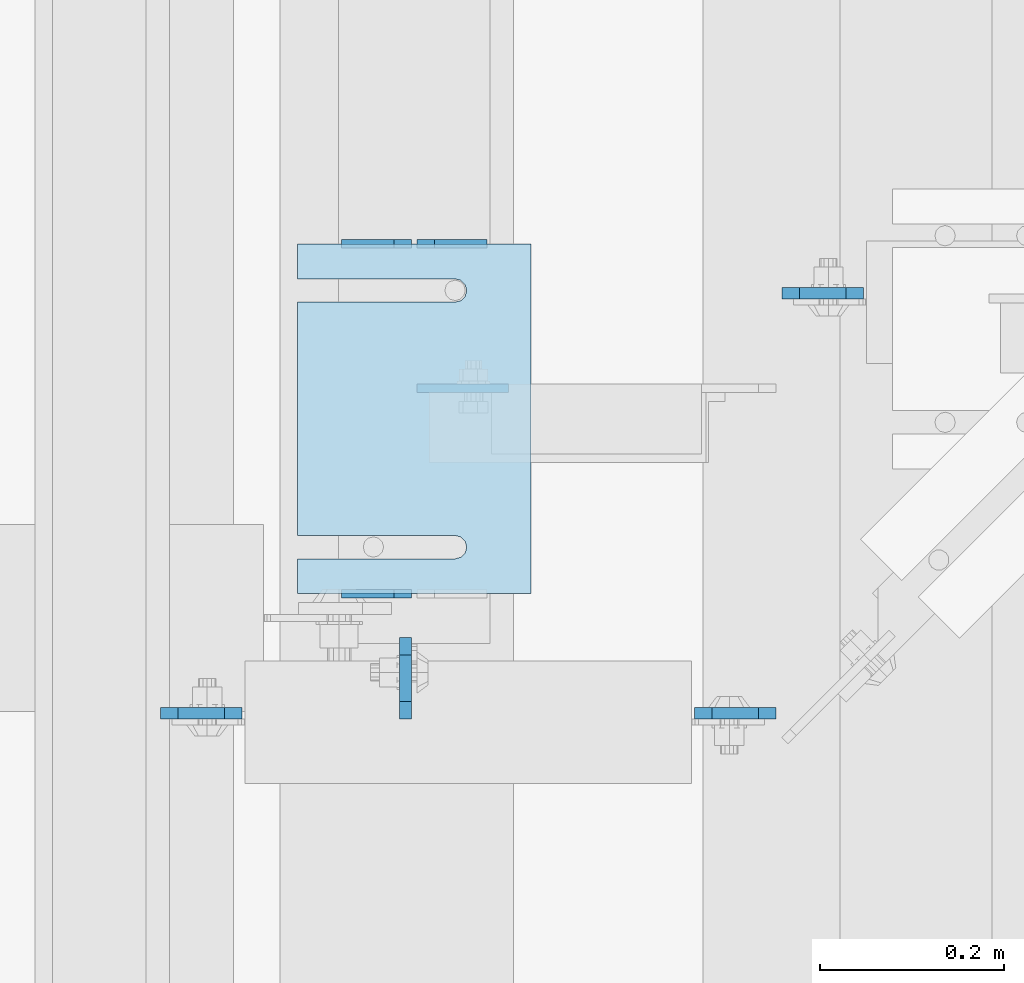
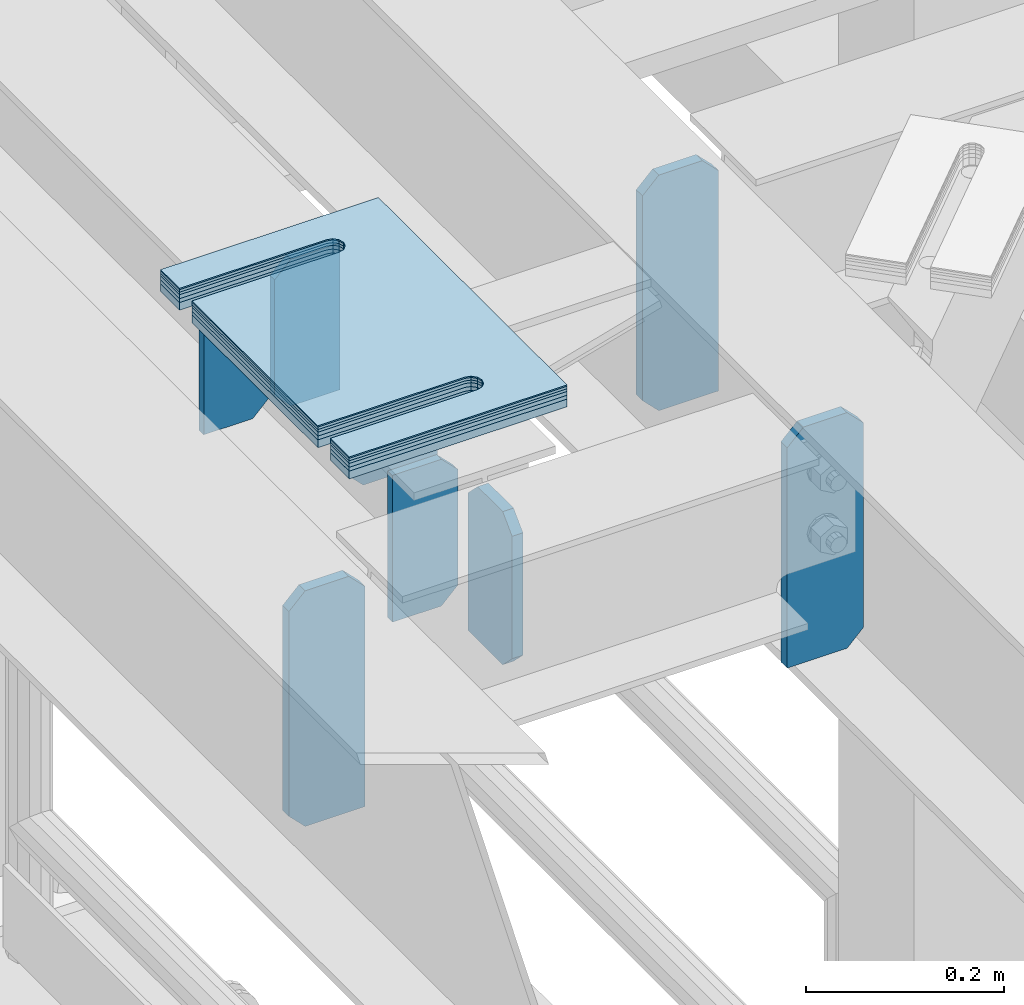
# One storey, part 1717 of 1876: 14 plates, 10 elements without a shape of their own.
"""IFC2X3 building model written with IfcOpenShell, lengths in millimetres."""

from ifc_helpers import new_model, si_unit, frame, origin_with_axes, place, context, subcontext, project, spatial, faceted_brep, material, type_object, element, aggregate, save


model = new_model("IFC2X3")

# Units and contexts
model_context = context("Model", 3, precision=1e-05, world=origin_with_axes())
body_context = subcontext(model_context, "Body", "Model", "MODEL_VIEW")
ifc_project = project(units=[si_unit("LENGTHUNIT", "METRE", prefix="MILLI"), si_unit("AREAUNIT", "SQUARE_METRE"), si_unit("VOLUMEUNIT", "CUBIC_METRE"), si_unit("MASSUNIT", "GRAM", prefix="KILO"), si_unit("TIMEUNIT", "SECOND"), si_unit("PLANEANGLEUNIT", "RADIAN"), si_unit("SOLIDANGLEUNIT", "STERADIAN"), si_unit("THERMODYNAMICTEMPERATUREUNIT", "DEGREE_CELSIUS"), si_unit("LUMINOUSINTENSITYUNIT", "LUMEN")], contexts=[model_context])

# Site, building, storey
site_placement = place(None, origin_with_axes())
site = spatial("IfcSite", under=ifc_project, at=site_placement, CompositionType="ELEMENT")
building_placement = place(site_placement, origin_with_axes())
building = spatial("IfcBuilding", under=site, at=building_placement, Name="Undefined", CompositionType="ELEMENT")
storey_placement = place(building_placement, origin_with_axes())
storey = spatial("IfcBuildingStorey", under=building, at=storey_placement, Name="Undefined", CompositionType="ELEMENT", Elevation=0.0)

# Assembly, plates
assembly_1_placement = place(storey_placement, origin_with_axes())
assembly_1 = element("IfcElementAssembly", 1, at=assembly_1_placement, inside=storey, Name="BEAM", AssemblyPlace="NOTDEFINED", PredefinedType="RIGID_FRAME")
ifc_material = material(Name="STEEL/A36")
plate_type_1 = type_object("IfcPlateType", PredefinedType="NOTDEFINED")
plate_1_placement = place(assembly_1_placement, frame((5102.22401450963, 6273.20592206104, 17792.7), z_axis=(0.0, 0.0, 1.0), x_axis=(-1.0, 0.0, 0.0)))
plate_1 = element("IfcPlate", 2, at=plate_1_placement, type_object=plate_type_1, material=ifc_material, Name="PLATE", context=body_context, shape_type="Brep", body=[
    faceted_brep([(0.0, -4.76249999999982, 19.0499992370605), (0.0, -4.76249999999982, 161.925006866455), (0.0, 4.76249999999982, 161.925006866455), (0.0, 4.76249999999982, 19.0499992370605), (19.0499992370605, -4.76249999999982, 180.975006103516), (19.0499992370605, 4.76249999999982, 180.975006103516), (76.1999969482422, -4.76249999999982, 180.975006103516), (76.1999969482422, 4.76249999999982, 180.975006103516), (76.1999969482422, -4.76250000000073, 0.0), (76.1999969482422, 4.76250000000073, 0.0), (19.0499992370605, -4.76249999999982, 0.0), (19.0499992370605, 4.76249999999982, 0.0)], [[[0, 1, 2, 3]], [[1, 4, 5, 2]], [[4, 6, 7, 5]], [[6, 8, 9, 7]], [[8, 10, 11, 9]], [[10, 0, 3, 11]], [[5, 7, 9, 11, 3, 2]], [[10, 8, 6, 4, 1, 0]]]),
])
plate_2_placement = place(assembly_1_placement, frame((5184.77401450963, 6654.2043980711, 17792.7), z_axis=(0.0, 0.0, 1.0), x_axis=(-1.0, 0.0, 0.0)))
plate_2 = element("IfcPlate", 3, at=plate_2_placement, type_object=plate_type_1, material=ifc_material, Name="PLATE", context=body_context, shape_type="Brep", body=[
    faceted_brep([(0.0, -4.76249999999982, 0.0), (0.0, -4.76249999999982, 180.975006103516), (0.0, 4.76249999999982, 180.975006103516), (0.0, 4.76249999999982, 0.0), (57.1499977111816, -4.76249999999982, 180.975006103516), (57.1499977111816, 4.76249999999982, 180.975006103516), (76.1999969482422, -4.76249999999982, 161.925006866455), (76.1999969482422, 4.76249999999982, 161.925006866455), (76.1999969482422, -4.76249999999982, 19.0499992370605), (76.1999969482422, 4.76249999999982, 19.0499992370605), (57.1499977111816, -4.76249999999982, 0.0), (57.1499977111816, 4.76249999999982, 0.0)], [[[0, 1, 2, 3]], [[1, 4, 5, 2]], [[4, 6, 7, 5]], [[6, 8, 9, 7]], [[8, 10, 11, 9]], [[10, 0, 3, 11]], [[5, 7, 9, 11, 3, 2]], [[10, 8, 6, 4, 1, 0]]]),
])
plate_3_placement = place(assembly_1_placement, frame((5102.22401450963, 6654.2043980711, 17792.7), z_axis=(0.0, 0.0, 1.0), x_axis=(-1.0, 0.0, 0.0)))
plate_3 = element("IfcPlate", 4, at=plate_3_placement, type_object=plate_type_1, material=ifc_material, Name="PLATE", context=body_context, shape_type="Brep", body=[
    faceted_brep([(0.0, -4.76249999999982, 19.0499992370605), (0.0, -4.76249999999982, 161.925006866455), (0.0, 4.76249999999982, 161.925006866455), (0.0, 4.76249999999982, 19.0499992370605), (19.0499992370605, -4.76249999999982, 180.975006103516), (19.0499992370605, 4.76249999999982, 180.975006103516), (76.1999969482422, -4.76249999999982, 180.975006103516), (76.1999969482422, 4.76249999999982, 180.975006103516), (76.1999969482422, -4.76250000000073, 0.0), (76.1999969482422, 4.76250000000073, 0.0), (19.0499992370605, -4.76249999999982, 0.0), (19.0499992370605, 4.76249999999982, 0.0)], [[[0, 1, 2, 3]], [[1, 4, 5, 2]], [[4, 6, 7, 5]], [[6, 8, 9, 7]], [[8, 10, 11, 9]], [[10, 0, 3, 11]], [[5, 7, 9, 11, 3, 2]], [[10, 8, 6, 4, 1, 0]]]),
])
plate_type_2 = type_object("IfcPlateType", PredefinedType="NOTDEFINED")
plate_4_placement = place(assembly_1_placement, frame((5108.57399250517, 6497.04279828961, 17882.089493609), z_axis=(1.0, 0.0, 0.0), x_axis=(0.0, 0.0, -1.0)))
plate_4 = element("IfcPlate", 5, at=plate_4_placement, type_object=plate_type_2, material=ifc_material, Name="PLATE", context=body_context, shape_type="Brep", body=[
    faceted_brep([(0.0, -4.76249999999982, 0.0), (6.45964610157534e-06, -4.76250000002437, 99.4752502441406), (6.45964610157534e-06, 4.76249999997526, 99.4752502441424), (0.0, 4.76249999999982, 0.0), (89.3894958496094, -4.76250000002437, 99.4752502441406), (89.3894958496094, 4.76249999997526, 99.4752502441424), (89.3894891942582, -4.76250000000346, 12.6999998092715), (89.3894891942582, 4.76249999999709, 12.6999998092733), (76.6894884109497, -4.76249999999982, 5.45696821063757e-12), (76.6894884109497, 4.76249999999982, 7.27595761418343e-12)], [[[0, 1, 2, 3]], [[1, 4, 5, 2]], [[4, 6, 7, 5]], [[6, 8, 9, 7]], [[8, 0, 3, 9]], [[5, 7, 9, 3, 2]], [[8, 6, 4, 1, 0]]]),
])
aggregate(assembly_1, [plate_1, plate_2, plate_3, plate_4])

assembly_2_placement = place(storey_placement, origin_with_axes())
assembly_2 = element("IfcElementAssembly", 6, at=assembly_2_placement, inside=storey, Name="BEAM", AssemblyPlace="NOTDEFINED", PredefinedType="RIGID_FRAME")
plate_type_3 = type_object("IfcPlateType", PredefinedType="NOTDEFINED")
plate_5_placement = place(assembly_2_placement, frame((5505.45, 6600.23089609146, 17681.575), z_axis=(0.0, 0.0, 1.0), x_axis=(1.0, 0.0, 0.0)))
plate_5 = element("IfcPlate", 7, at=plate_5_placement, type_object=plate_type_3, material=ifc_material, Name="PLATE", context=body_context, shape_type="Brep", body=[
    faceted_brep([(0.0, -6.35000000000196, 19.0499992370605), (0.0, -6.35000000000036, 271.462512969971), (0.0, 6.35000000000036, 271.462512969971), (0.0, 6.35000000000105, 19.0499992370605), (19.0499992370605, -6.35000000000036, 290.512512207031), (19.0499992370605, 6.35000000000036, 290.512512207031), (69.8500003814697, -6.34999999999991, 290.512512207031), (69.8500003814697, 6.34999999999991, 290.512512207031), (88.9000015258789, -6.35000000000036, 271.462512969971), (88.9000015258789, 6.35000000000036, 271.462512969971), (88.9000015258789, -6.34999999999991, 0.0), (88.9000015258789, 6.34999999999991, 0.0), (19.0499992370642, -6.35000000000105, 0.0), (19.0499992370633, 6.35000000000105, 0.0)], [[[0, 1, 2, 3]], [[1, 4, 5, 2]], [[4, 6, 7, 5]], [[6, 8, 9, 7]], [[8, 10, 11, 9]], [[10, 12, 13, 11]], [[12, 0, 3, 13]], [[5, 7, 9, 11, 13, 3, 2]], [[12, 10, 8, 6, 4, 1, 0]]]),
])
plate_6_placement = place(assembly_2_placement, frame((5499.1, 6143.03089609146, 17681.575), z_axis=(0.0, 0.0, 1.0), x_axis=(-1.0, 0.0, 0.0)))
plate_6 = element("IfcPlate", 8, at=plate_6_placement, type_object=plate_type_3, material=ifc_material, Name="PLATE", context=body_context, shape_type="Brep", body=[
    faceted_brep([(0.0, -6.35000000000196, 19.0499992370605), (0.0, -6.35000000000036, 271.462512969971), (0.0, 6.35000000000036, 271.462512969971), (0.0, 6.35000000000105, 19.0499992370605), (19.0499992370605, -6.35000000000036, 290.512512207031), (19.0499992370605, 6.35000000000036, 290.512512207031), (69.8500003814697, -6.34999999999991, 290.512512207031), (69.8500003814697, 6.34999999999991, 290.512512207031), (88.9000015258789, -6.35000000000036, 271.462512969971), (88.9000015258789, 6.35000000000036, 271.462512969971), (88.9000015258789, -6.34999999999991, 0.0), (88.9000015258789, 6.34999999999991, 0.0), (19.0499992370642, -6.35000000000105, 0.0), (19.0499992370633, 6.35000000000105, 0.0)], [[[0, 1, 2, 3]], [[1, 4, 5, 2]], [[4, 6, 7, 5]], [[6, 8, 9, 7]], [[8, 10, 11, 9]], [[10, 12, 13, 11]], [[12, 0, 3, 13]], [[5, 7, 9, 11, 13, 3, 2]], [[12, 10, 8, 6, 4, 1, 0]]]),
])
aggregate(assembly_2, [plate_5, plate_6])

# Assembly, plate
assembly_3_placement = place(storey_placement, origin_with_axes())
assembly_3 = element("IfcElementAssembly", 9, at=assembly_3_placement, inside=storey, Name="BEAM", AssemblyPlace="NOTDEFINED", PredefinedType="RIGID_FRAME")
plate_7_placement = place(assembly_3_placement, frame((4829.175, 6143.03089609146, 17683.1625), z_axis=(0.0, 0.0, 1.0), x_axis=(1.0, 0.0, 0.0)))
plate_7 = element("IfcPlate", 10, at=plate_7_placement, type_object=plate_type_3, material=ifc_material, Name="PLATE", context=body_context, shape_type="Brep", body=[
    faceted_brep([(0.0, -6.35000000000196, 19.0499992370605), (0.0, -6.35000000000036, 271.462512969971), (0.0, 6.35000000000036, 271.462512969971), (0.0, 6.35000000000105, 19.0499992370605), (19.0499992370605, -6.35000000000036, 290.512512207031), (19.0499992370605, 6.35000000000036, 290.512512207031), (69.8500003814697, -6.34999999999991, 290.512512207031), (69.8500003814697, 6.34999999999991, 290.512512207031), (88.9000015258789, -6.35000000000036, 271.462512969971), (88.9000015258789, 6.35000000000036, 271.462512969971), (88.9000015258789, -6.34999999999991, 0.0), (88.9000015258789, 6.34999999999991, 0.0), (19.0499992370642, -6.35000000000105, 0.0), (19.0499992370633, 6.35000000000105, 0.0)], [[[0, 1, 2, 3]], [[1, 4, 5, 2]], [[4, 6, 7, 5]], [[6, 8, 9, 7]], [[8, 10, 11, 9]], [[10, 12, 13, 11]], [[12, 0, 3, 13]], [[5, 7, 9, 11, 13, 3, 2]], [[12, 10, 8, 6, 4, 1, 0]]]),
])
aggregate(assembly_3, [plate_7])

assembly_4_placement = place(storey_placement, origin_with_axes())
assembly_4 = element("IfcElementAssembly", 11, at=assembly_4_placement, inside=storey, Name="BEAM", AssemblyPlace="NOTDEFINED", PredefinedType="RIGID_FRAME")
plate_8_placement = place(assembly_4_placement, frame((5095.87401441426, 6136.68089599609, 17786.35), z_axis=(0.0, 0.0, 1.0), x_axis=(0.0, 1.0, 0.0)))
plate_8 = element("IfcPlate", 12, at=plate_8_placement, type_object=plate_type_3, material=ifc_material, Name="PLATE", context=body_context, shape_type="Brep", body=[
    faceted_brep([(0.0, -6.35000000000196, 19.0499992370605), (0.0, -6.34999999999991, 169.862506866455), (0.0, 6.34999999999991, 169.862506866455), (0.0, 6.35000000000105, 19.0499992370605), (19.0499992370605, -6.34999999999991, 188.912506103516), (19.0499992370605, 6.34999999999991, 188.912506103516), (69.8500022888184, -6.34999999999991, 188.912506103516), (69.8500022888184, 6.34999999999991, 188.912506103516), (88.9000015258789, -6.34999999999991, 169.862506866455), (88.9000015258789, 6.34999999999991, 169.862506866455), (88.9000015258789, -6.34999999999991, 0.0), (88.9000015258789, 6.34999999999991, 0.0), (19.0499992370642, -6.35000000000105, 0.0), (19.0499992370633, 6.35000000000105, 0.0)], [[[0, 1, 2, 3]], [[1, 4, 5, 2]], [[4, 6, 7, 5]], [[6, 8, 9, 7]], [[8, 10, 11, 9]], [[10, 12, 13, 11]], [[12, 0, 3, 13]], [[5, 7, 9, 11, 13, 3, 2]], [[12, 10, 8, 6, 4, 1, 0]]]),
])
aggregate(assembly_4, [plate_8])

assembly_5_placement = place(storey_placement, origin_with_axes())
assembly_5 = element("IfcElementAssembly", 13, at=assembly_5_placement, inside=storey, Name="SHIM PLATE", AssemblyPlace="NOTDEFINED", PredefinedType="RIGID_FRAME")
plate_type_4 = type_object("IfcPlateType", PredefinedType="NOTDEFINED")
plate_9_placement = place(assembly_5_placement, frame((5232.39982977416, 6654.20335755462, 18007.0115), z_axis=(-1.0, 0.0, 0.0), x_axis=(0.0, -1.0, 0.0)))
plate_9 = element("IfcPlate", 14, at=plate_9_placement, type_object=plate_type_4, material=ifc_material, Name="SHIM PLATE", context=body_context, shape_type="Brep", body=[
    faceted_brep([(38.1710562683074, -1.58750000000146, 253.999557495119), (38.1732778844053, -1.58750000000146, 82.6182316462764), (38.1732778844053, 1.58750000000146, 82.6182316462764), (38.1710562683074, 1.58750000000146, 253.999557495119), (39.8747477728821, -1.58750000000146, 76.2682283464169), (39.8747477728821, 1.58750000000146, 76.2682283464169), (44.523266268131, -1.58750000000146, 71.6196998169826), (44.523266268131, 1.58750000000146, 71.6196998169826), (50.8732658952267, -1.58750000000146, 69.9182162215529), (50.8732658952267, 1.58750000000146, 69.9182162215529), (57.2232684284982, -1.58750000000146, 71.6196889709886), (57.2232684284982, 1.58750000000146, 71.6196889709886), (61.8717948635667, -1.58750000000146, 76.2682095606051), (61.8717948635667, 1.58750000000146, 76.2682095606051), (63.5732755980398, -1.58750000000146, 82.6182099542939), (63.5732755980398, 1.58750000000146, 82.6182099542939), (63.5710539816291, -1.58750000000146, 253.999557596195), (63.5710539816291, 1.58750000000146, 253.99955749512), (9.09494701772928e-13, -1.58750000000146, 4.54747350886464e-13), (1.89071320164658e-05, -1.58750000000146, 253.999557495117), (1.89071320164658e-05, 1.58750000000146, 253.999557495117), (9.09494701772928e-13, 1.58750000000146, 4.54747350886464e-13), (380.998474121094, -1.58750000000146, -2.41016095969826e-11), (380.998474121094, 1.58750000000146, -2.41016095969826e-11), (380.998504638661, -1.58750000000146, 253.999557495133), (380.998504638661, 1.58750000000146, 253.999557495133), (342.971054337228, 1.58750000000146, 253.999557495132), (342.971054337228, -1.58750000000146, 253.999557596208), (342.973275782132, 1.58750000000146, 82.6182252130961), (342.973275782132, -1.58750000000146, 82.6182252130961), (341.271801399192, 1.58750000000146, 76.2682205744086), (341.271801399192, -1.58750000000146, 76.2682205744086), (336.623277411347, 1.58750000000146, 71.6196940636119), (336.623277411347, -1.58750000000146, 71.6196940636119), (330.273273696123, 1.58750000000146, 69.9182162342554), (330.273273696123, -1.58750000000146, 69.9182162342554), (323.923270846187, 1.58750000000146, 71.6196972929051), (323.923270846187, -1.58750000000146, 71.6196972929051), (319.274749222349, 1.58750000000146, 76.2682261677069), (319.274749222349, -1.58750000000146, 76.2682261677069), (317.573278068704, 1.58750000000146, 82.6182316716777), (317.573278068704, -1.58750000000146, 82.6182316716777), (317.571056623908, -1.58750000000146, 253.99955749513), (317.571056623908, 1.58750000000146, 253.99955749513)], [[[0, 1, 2, 3]], [[4, 5, 2, 1]], [[6, 7, 5, 4]], [[8, 9, 7, 6]], [[10, 11, 9, 8]], [[12, 13, 11, 10]], [[14, 15, 13, 12]], [[16, 17, 15, 14]], [[18, 19, 20, 21]], [[22, 18, 21, 23]], [[24, 22, 23, 25]], [[24, 25, 26, 27]], [[27, 26, 28, 29]], [[29, 28, 30, 31]], [[31, 30, 32, 33]], [[33, 32, 34, 35]], [[35, 34, 36, 37]], [[37, 36, 38, 39]], [[39, 38, 40, 41]], [[42, 41, 40, 43]], [[12, 10, 8, 6, 4, 1, 0, 19, 18, 22, 24, 27, 29, 31, 33, 35, 37, 39, 41, 42, 16, 14]], [[20, 19, 0, 3]], [[43, 40, 38, 36, 34, 32, 30, 28, 26, 25, 23, 21, 20, 3, 2, 5, 7, 9, 11, 13, 15, 17]], [[42, 43, 17, 16]]]),
])
aggregate(assembly_5, [plate_9])

assembly_6_placement = place(storey_placement, origin_with_axes())
assembly_6 = element("IfcElementAssembly", 15, at=assembly_6_placement, inside=storey, Name="SHIM PLATE", AssemblyPlace="NOTDEFINED", PredefinedType="RIGID_FRAME")
plate_10_placement = place(assembly_6_placement, frame((5232.39982977416, 6654.20335755462, 18003.8365), z_axis=(-1.0, 0.0, 0.0), x_axis=(0.0, -1.0, 0.0)))
plate_10 = element("IfcPlate", 16, at=plate_10_placement, type_object=plate_type_4, material=ifc_material, Name="SHIM PLATE", context=body_context, shape_type="Brep", body=[
    faceted_brep([(38.1710562683074, -1.58750000000146, 253.999557495119), (38.1732778844053, -1.58750000000146, 82.6182316462764), (38.1732778844053, 1.58750000000146, 82.6182316462764), (38.1710562683074, 1.58750000000146, 253.999557495119), (39.8747477728821, -1.58750000000146, 76.2682283464169), (39.8747477728821, 1.58750000000146, 76.2682283464169), (44.523266268131, -1.58750000000146, 71.6196998169826), (44.523266268131, 1.58750000000146, 71.6196998169826), (50.8732658952267, -1.58750000000146, 69.9182162215529), (50.8732658952267, 1.58750000000146, 69.9182162215529), (57.2232684284982, -1.58750000000146, 71.6196889709886), (57.2232684284982, 1.58750000000146, 71.6196889709886), (61.8717948635667, -1.58750000000146, 76.2682095606051), (61.8717948635667, 1.58750000000146, 76.2682095606051), (63.5732755980398, -1.58750000000146, 82.6182099542939), (63.5732755980398, 1.58750000000146, 82.6182099542939), (63.5710539816291, -1.58750000000146, 253.999557596195), (63.5710539816291, 1.58750000000146, 253.99955749512), (9.09494701772928e-13, -1.58750000000146, 4.54747350886464e-13), (1.89071320164658e-05, -1.58750000000146, 253.999557495117), (1.89071320164658e-05, 1.58750000000146, 253.999557495117), (9.09494701772928e-13, 1.58750000000146, 4.54747350886464e-13), (380.998474121094, -1.58750000000146, -2.41016095969826e-11), (380.998474121094, 1.58750000000146, -2.41016095969826e-11), (380.998504638661, -1.58750000000146, 253.999557495133), (380.998504638661, 1.58750000000146, 253.999557495133), (342.971054337228, 1.58750000000146, 253.999557495132), (342.971054337228, -1.58750000000146, 253.999557596208), (342.973275782132, 1.58750000000146, 82.6182252130961), (342.973275782132, -1.58750000000146, 82.6182252130961), (341.271801399192, 1.58750000000146, 76.2682205744086), (341.271801399192, -1.58750000000146, 76.2682205744086), (336.623277411347, 1.58750000000146, 71.6196940636119), (336.623277411347, -1.58750000000146, 71.6196940636119), (330.273273696123, 1.58750000000146, 69.9182162342554), (330.273273696123, -1.58750000000146, 69.9182162342554), (323.923270846187, 1.58750000000146, 71.6196972929051), (323.923270846187, -1.58750000000146, 71.6196972929051), (319.274749222349, 1.58750000000146, 76.2682261677069), (319.274749222349, -1.58750000000146, 76.2682261677069), (317.573278068704, 1.58750000000146, 82.6182316716777), (317.573278068704, -1.58750000000146, 82.6182316716777), (317.571056623908, -1.58750000000146, 253.99955749513), (317.571056623908, 1.58750000000146, 253.99955749513)], [[[0, 1, 2, 3]], [[4, 5, 2, 1]], [[6, 7, 5, 4]], [[8, 9, 7, 6]], [[10, 11, 9, 8]], [[12, 13, 11, 10]], [[14, 15, 13, 12]], [[16, 17, 15, 14]], [[18, 19, 20, 21]], [[22, 18, 21, 23]], [[24, 22, 23, 25]], [[24, 25, 26, 27]], [[27, 26, 28, 29]], [[29, 28, 30, 31]], [[31, 30, 32, 33]], [[33, 32, 34, 35]], [[35, 34, 36, 37]], [[37, 36, 38, 39]], [[39, 38, 40, 41]], [[42, 41, 40, 43]], [[12, 10, 8, 6, 4, 1, 0, 19, 18, 22, 24, 27, 29, 31, 33, 35, 37, 39, 41, 42, 16, 14]], [[20, 19, 0, 3]], [[43, 40, 38, 36, 34, 32, 30, 28, 26, 25, 23, 21, 20, 3, 2, 5, 7, 9, 11, 13, 15, 17]], [[42, 43, 17, 16]]]),
])
aggregate(assembly_6, [plate_10])

assembly_7_placement = place(storey_placement, origin_with_axes())
assembly_7 = element("IfcElementAssembly", 17, at=assembly_7_placement, inside=storey, Name="SHIM PLATE", AssemblyPlace="NOTDEFINED", PredefinedType="RIGID_FRAME")
plate_type_5 = type_object("IfcPlateType", PredefinedType="NOTDEFINED")
plate_11_placement = place(assembly_7_placement, frame((5232.39982977416, 6654.20335755462, 18009.3925), z_axis=(-1.0, 0.0, 0.0), x_axis=(0.0, -1.0, 0.0)))
plate_11 = element("IfcPlate", 18, at=plate_11_placement, type_object=plate_type_5, material=ifc_material, Name="SHIM PLATE", context=body_context, shape_type="Brep", body=[
    faceted_brep([(38.1710562683074, -0.793499999999767, 253.999557495119), (38.1732778844053, -0.793499999999767, 82.6182316462764), (38.1732778844053, 0.793499999999767, 82.6182316462764), (38.1710562683074, 0.793499999999767, 253.999557495119), (39.8747477728821, -0.793499999999767, 76.2682283464169), (39.8747477728821, 0.793499999999767, 76.2682283464169), (44.523266268131, -0.793499999999767, 71.6196998169826), (44.523266268131, 0.793499999999767, 71.6196998169826), (50.8732658952267, -0.793499999999767, 69.9182162215529), (50.8732658952267, 0.793499999999767, 69.9182162215529), (57.2232684284982, -0.793499999999767, 71.6196889709886), (57.2232684284982, 0.793499999999767, 71.6196889709886), (61.8717948635667, -0.793499999999767, 76.2682095606051), (61.8717948635667, 0.793499999999767, 76.2682095606051), (63.5732755980398, -0.793499999999767, 82.6182099542939), (63.5732755980398, 0.793499999999767, 82.6182099542939), (63.5710539816291, -0.793499999999767, 253.999557596195), (63.5710539816291, 0.793499999999767, 253.99955749512), (9.09494701772928e-13, -0.793499999999767, 0.0), (1.89070156011439e-05, -0.793499999999767, 253.999557495117), (1.89070156011439e-05, 0.793499999999767, 253.999557495117), (9.09494701772928e-13, 0.793499999999767, 0.0), (380.998474121094, -0.793499999999767, -2.41016095969826e-11), (380.998474121094, 0.793499999999767, -2.41016095969826e-11), (380.998504638661, -0.793499999999767, 253.999557495133), (380.998504638661, 0.793499999999767, 253.999557495133), (342.971054337228, 0.793499999999767, 253.999557495132), (342.971054337228, -0.793499999999767, 253.999557596208), (342.973275782132, 0.793499999999767, 82.6182252130961), (342.973275782132, -0.793499999999767, 82.6182252130961), (341.271801399192, 0.793499999999767, 76.2682205744086), (341.271801399192, -0.793499999999767, 76.2682205744086), (336.623277411347, 0.793499999999767, 71.6196940636119), (336.623277411347, -0.793499999999767, 71.6196940636119), (330.273273696123, 0.793499999999767, 69.9182162342554), (330.273273696123, -0.793499999999767, 69.9182162342554), (323.923270846187, 0.793499999999767, 71.6196972929051), (323.923270846187, -0.793499999999767, 71.6196972929051), (319.274749222349, 0.793499999999767, 76.2682261677069), (319.274749222349, -0.793499999999767, 76.2682261677069), (317.573278068704, 0.793499999999767, 82.6182316716777), (317.573278068704, -0.793499999999767, 82.6182316716777), (317.571056623908, -0.793499999999767, 253.99955749513), (317.571056623908, 0.793499999999767, 253.99955749513)], [[[0, 1, 2, 3]], [[4, 5, 2, 1]], [[6, 7, 5, 4]], [[8, 9, 7, 6]], [[10, 11, 9, 8]], [[12, 13, 11, 10]], [[14, 15, 13, 12]], [[16, 17, 15, 14]], [[18, 19, 20, 21]], [[22, 18, 21, 23]], [[24, 22, 23, 25]], [[24, 25, 26, 27]], [[27, 26, 28, 29]], [[29, 28, 30, 31]], [[31, 30, 32, 33]], [[33, 32, 34, 35]], [[35, 34, 36, 37]], [[37, 36, 38, 39]], [[39, 38, 40, 41]], [[42, 41, 40, 43]], [[12, 10, 8, 6, 4, 1, 0, 19, 18, 22, 24, 27, 29, 31, 33, 35, 37, 39, 41, 42, 16, 14]], [[20, 19, 0, 3]], [[43, 40, 38, 36, 34, 32, 30, 28, 26, 25, 23, 21, 20, 3, 2, 5, 7, 9, 11, 13, 15, 17]], [[42, 43, 17, 16]]]),
])
aggregate(assembly_7, [plate_11])

assembly_8_placement = place(storey_placement, origin_with_axes())
assembly_8 = element("IfcElementAssembly", 19, at=assembly_8_placement, inside=storey, Name="SHIM PLATE", AssemblyPlace="NOTDEFINED", PredefinedType="RIGID_FRAME")
plate_type_6 = type_object("IfcPlateType", PredefinedType="NOTDEFINED")
plate_12_placement = place(assembly_8_placement, frame((5232.39982977416, 6654.20335755462, 17999.868), z_axis=(-1.0, 0.0, 0.0), x_axis=(0.0, -1.0, 0.0)))
plate_12 = element("IfcPlate", 20, at=plate_12_placement, type_object=plate_type_6, material=ifc_material, Name="SHIM PLATE", context=body_context, shape_type="Brep", body=[
    faceted_brep([(38.1710562683056, -2.38100000000122, 253.999557495119), (38.1732778844034, -2.38100000000122, 82.6182316462764), (38.1732778844034, 2.38100000000122, 82.6182316462764), (38.1710562683056, 2.38100000000122, 253.999557495119), (39.8747477728803, -2.38100000000122, 76.2682283464169), (39.8747477728803, 2.38100000000122, 76.2682283464169), (44.5232662681292, -2.38100000000122, 71.6196998169826), (44.5232662681292, 2.38100000000122, 71.6196998169826), (50.8732658952249, -2.38100000000122, 69.9182162215529), (50.8732658952249, 2.38100000000122, 69.9182162215529), (57.2232684284963, -2.38100000000122, 71.6196889709886), (57.2232684284963, 2.38100000000122, 71.6196889709886), (61.8717948635649, -2.38100000000122, 76.2682095606051), (61.8717948635649, 2.38100000000122, 76.2682095606051), (63.573275598038, -2.38100000000122, 82.6182099542939), (63.573275598038, 2.38100000000122, 82.6182099542939), (63.5710539816273, -2.38100000000122, 253.999557596195), (63.5710539816273, 2.38100000000122, 253.99955749512), (0.0, -2.38100000000122, 4.54747350886464e-13), (1.89072484317876e-05, -2.38100000000122, 253.999557495117), (1.89072484317876e-05, 2.38100000000122, 253.999557495117), (0.0, 2.38100000000122, 4.54747350886464e-13), (380.998474121094, -2.38100000000122, -2.41016095969826e-11), (380.998474121094, 2.38100000000122, -2.41016095969826e-11), (380.998504638661, -2.38100000000122, 253.999557495133), (380.998504638661, 2.38100000000122, 253.999557495133), (342.971054337227, 2.38100000000122, 253.999557495132), (342.971054337227, -2.38100000000122, 253.999557596208), (342.97327578213, 2.38100000000122, 82.6182252130961), (342.97327578213, -2.38100000000122, 82.6182252130961), (341.27180139919, 2.38100000000122, 76.2682205744086), (341.27180139919, -2.38100000000122, 76.2682205744086), (336.623277411345, 2.38100000000122, 71.6196940636119), (336.623277411345, -2.38100000000122, 71.6196940636119), (330.273273696122, 2.38100000000122, 69.9182162342554), (330.273273696122, -2.38100000000122, 69.9182162342554), (323.923270846185, 2.38100000000122, 71.6196972929051), (323.923270846185, -2.38100000000122, 71.6196972929051), (319.274749222347, 2.38100000000122, 76.2682261677069), (319.274749222347, -2.38100000000122, 76.2682261677069), (317.573278068702, 2.38100000000122, 82.6182316716777), (317.573278068702, -2.38100000000122, 82.6182316716777), (317.571056623906, -2.38100000000122, 253.99955749513), (317.571056623906, 2.38100000000122, 253.99955749513)], [[[0, 1, 2, 3]], [[4, 5, 2, 1]], [[6, 7, 5, 4]], [[8, 9, 7, 6]], [[10, 11, 9, 8]], [[12, 13, 11, 10]], [[14, 15, 13, 12]], [[16, 17, 15, 14]], [[18, 19, 20, 21]], [[22, 18, 21, 23]], [[24, 22, 23, 25]], [[24, 25, 26, 27]], [[27, 26, 28, 29]], [[29, 28, 30, 31]], [[31, 30, 32, 33]], [[33, 32, 34, 35]], [[35, 34, 36, 37]], [[37, 36, 38, 39]], [[39, 38, 40, 41]], [[42, 41, 40, 43]], [[12, 10, 8, 6, 4, 1, 0, 19, 18, 22, 24, 27, 29, 31, 33, 35, 37, 39, 41, 42, 16, 14]], [[20, 19, 0, 3]], [[43, 40, 38, 36, 34, 32, 30, 28, 26, 25, 23, 21, 20, 3, 2, 5, 7, 9, 11, 13, 15, 17]], [[42, 43, 17, 16]]]),
])
aggregate(assembly_8, [plate_12])

assembly_9_placement = place(storey_placement, origin_with_axes())
assembly_9 = element("IfcElementAssembly", 21, at=assembly_9_placement, inside=storey, Name="SHIM PLATE", AssemblyPlace="NOTDEFINED", PredefinedType="RIGID_FRAME")
plate_13_placement = place(assembly_9_placement, frame((5232.39982977416, 6654.20335755462, 17995.106), z_axis=(-1.0, 0.0, 0.0), x_axis=(0.0, -1.0, 0.0)))
plate_13 = element("IfcPlate", 22, at=plate_13_placement, type_object=plate_type_6, material=ifc_material, Name="SHIM PLATE", context=body_context, shape_type="Brep", body=[
    faceted_brep([(38.1710562683056, -2.38100000000122, 253.999557495119), (38.1732778844034, -2.38100000000122, 82.6182316462764), (38.1732778844034, 2.38100000000122, 82.6182316462764), (38.1710562683056, 2.38100000000122, 253.999557495119), (39.8747477728803, -2.38100000000122, 76.2682283464169), (39.8747477728803, 2.38100000000122, 76.2682283464169), (44.5232662681292, -2.38100000000122, 71.6196998169826), (44.5232662681292, 2.38100000000122, 71.6196998169826), (50.8732658952249, -2.38100000000122, 69.9182162215529), (50.8732658952249, 2.38100000000122, 69.9182162215529), (57.2232684284963, -2.38100000000122, 71.6196889709886), (57.2232684284963, 2.38100000000122, 71.6196889709886), (61.8717948635649, -2.38100000000122, 76.2682095606051), (61.8717948635649, 2.38100000000122, 76.2682095606051), (63.573275598038, -2.38100000000122, 82.6182099542939), (63.573275598038, 2.38100000000122, 82.6182099542939), (63.5710539816273, -2.38100000000122, 253.999557596195), (63.5710539816273, 2.38100000000122, 253.99955749512), (0.0, -2.38100000000122, 4.54747350886464e-13), (1.89072484317876e-05, -2.38100000000122, 253.999557495117), (1.89072484317876e-05, 2.38100000000122, 253.999557495117), (0.0, 2.38100000000122, 4.54747350886464e-13), (380.998474121094, -2.38100000000122, -2.41016095969826e-11), (380.998474121094, 2.38100000000122, -2.41016095969826e-11), (380.998504638661, -2.38100000000122, 253.999557495133), (380.998504638661, 2.38100000000122, 253.999557495133), (342.971054337227, 2.38100000000122, 253.999557495132), (342.971054337227, -2.38100000000122, 253.999557596208), (342.97327578213, 2.38100000000122, 82.6182252130961), (342.97327578213, -2.38100000000122, 82.6182252130961), (341.27180139919, 2.38100000000122, 76.2682205744086), (341.27180139919, -2.38100000000122, 76.2682205744086), (336.623277411345, 2.38100000000122, 71.6196940636119), (336.623277411345, -2.38100000000122, 71.6196940636119), (330.273273696122, 2.38100000000122, 69.9182162342554), (330.273273696122, -2.38100000000122, 69.9182162342554), (323.923270846185, 2.38100000000122, 71.6196972929051), (323.923270846185, -2.38100000000122, 71.6196972929051), (319.274749222347, 2.38100000000122, 76.2682261677069), (319.274749222347, -2.38100000000122, 76.2682261677069), (317.573278068702, 2.38100000000122, 82.6182316716777), (317.573278068702, -2.38100000000122, 82.6182316716777), (317.571056623906, -2.38100000000122, 253.99955749513), (317.571056623906, 2.38100000000122, 253.99955749513)], [[[0, 1, 2, 3]], [[4, 5, 2, 1]], [[6, 7, 5, 4]], [[8, 9, 7, 6]], [[10, 11, 9, 8]], [[12, 13, 11, 10]], [[14, 15, 13, 12]], [[16, 17, 15, 14]], [[18, 19, 20, 21]], [[22, 18, 21, 23]], [[24, 22, 23, 25]], [[24, 25, 26, 27]], [[27, 26, 28, 29]], [[29, 28, 30, 31]], [[31, 30, 32, 33]], [[33, 32, 34, 35]], [[35, 34, 36, 37]], [[37, 36, 38, 39]], [[39, 38, 40, 41]], [[42, 41, 40, 43]], [[12, 10, 8, 6, 4, 1, 0, 19, 18, 22, 24, 27, 29, 31, 33, 35, 37, 39, 41, 42, 16, 14]], [[20, 19, 0, 3]], [[43, 40, 38, 36, 34, 32, 30, 28, 26, 25, 23, 21, 20, 3, 2, 5, 7, 9, 11, 13, 15, 17]], [[42, 43, 17, 16]]]),
])
aggregate(assembly_9, [plate_13])

assembly_10_placement = place(storey_placement, origin_with_axes())
assembly_10 = element("IfcElementAssembly", 23, at=assembly_10_placement, inside=storey, Name="SHIM PLATE", AssemblyPlace="NOTDEFINED", PredefinedType="RIGID_FRAME")
plate_type_7 = type_object("IfcPlateType", PredefinedType="NOTDEFINED")
plate_14_placement = place(assembly_10_placement, frame((5232.39982977416, 6654.20335755462, 17987.9625), z_axis=(-1.0, 0.0, 0.0), x_axis=(0.0, -1.0, 0.0)))
plate_14 = element("IfcPlate", 24, at=plate_14_placement, type_object=plate_type_7, material=ifc_material, Name="SHIM PLATE", context=body_context, shape_type="Brep", body=[
    faceted_brep([(38.1710562683074, -4.76250000000073, 253.999557495119), (38.1732778844053, -4.76250000000073, 82.6182316462764), (38.1732778844053, 4.76250000000073, 82.6182316462764), (38.1710562683074, 4.76250000000073, 253.999557495119), (39.8747477728821, -4.76250000000073, 76.2682283464169), (39.8747477728821, 4.76250000000073, 76.2682283464169), (44.523266268131, -4.76250000000073, 71.6196998169826), (44.523266268131, 4.76250000000073, 71.6196998169826), (50.8732658952267, -4.76250000000073, 69.9182162215529), (50.8732658952267, 4.76250000000073, 69.9182162215529), (57.2232684284982, -4.76250000000073, 71.6196889709886), (57.2232684284982, 4.76250000000073, 71.6196889709886), (61.8717948635667, -4.76250000000073, 76.2682095606051), (61.8717948635667, 4.76250000000073, 76.2682095606051), (63.5732755980398, -4.76250000000073, 82.6182099542939), (63.5732755980398, 4.76250000000073, 82.6182099542939), (63.5710539816291, -4.76250000000073, 253.999557596195), (63.5710539816291, 4.76250000000073, 253.99955749512), (0.0, -4.76249999999982, 0.0), (1.89073648471094e-05, -4.76250000000073, 253.999557495117), (1.89073648471094e-05, 4.76250000000073, 253.999557495117), (0.0, 4.76249999999982, 0.0), (380.998474121094, -4.76250000000073, -2.41016095969826e-11), (380.998474121094, 4.76250000000073, -2.41016095969826e-11), (380.998504638661, -4.76250000000073, 253.999557495133), (380.998504638661, 4.76250000000073, 253.999557495133), (342.971054337228, 4.76250000000073, 253.999557495132), (342.971054337228, -4.76250000000073, 253.999557596208), (342.973275782132, 4.76250000000073, 82.6182252130961), (342.973275782132, -4.76250000000073, 82.6182252130961), (341.271801399192, 4.76250000000073, 76.2682205744086), (341.271801399192, -4.76250000000073, 76.2682205744086), (336.623277411347, 4.76250000000073, 71.6196940636119), (336.623277411347, -4.76250000000073, 71.6196940636119), (330.273273696123, 4.76250000000073, 69.9182162342554), (330.273273696123, -4.76250000000073, 69.9182162342554), (323.923270846187, 4.76250000000073, 71.6196972929051), (323.923270846187, -4.76250000000073, 71.6196972929051), (319.274749222349, 4.76250000000073, 76.2682261677069), (319.274749222349, -4.76250000000073, 76.2682261677069), (317.573278068704, 4.76250000000073, 82.6182316716777), (317.573278068704, -4.76250000000073, 82.6182316716777), (317.571056623908, -4.76250000000073, 253.99955749513), (317.571056623908, 4.76250000000073, 253.99955749513)], [[[0, 1, 2, 3]], [[4, 5, 2, 1]], [[6, 7, 5, 4]], [[8, 9, 7, 6]], [[10, 11, 9, 8]], [[12, 13, 11, 10]], [[14, 15, 13, 12]], [[16, 17, 15, 14]], [[18, 19, 20, 21]], [[22, 18, 21, 23]], [[24, 22, 23, 25]], [[24, 25, 26, 27]], [[27, 26, 28, 29]], [[29, 28, 30, 31]], [[31, 30, 32, 33]], [[33, 32, 34, 35]], [[35, 34, 36, 37]], [[37, 36, 38, 39]], [[39, 38, 40, 41]], [[42, 41, 40, 43]], [[12, 10, 8, 6, 4, 1, 0, 19, 18, 22, 24, 27, 29, 31, 33, 35, 37, 39, 41, 42, 16, 14]], [[20, 19, 0, 3]], [[43, 40, 38, 36, 34, 32, 30, 28, 26, 25, 23, 21, 20, 3, 2, 5, 7, 9, 11, 13, 15, 17]], [[42, 43, 17, 16]]]),
])
aggregate(assembly_10, [plate_14])

save(model, "model.ifc")
